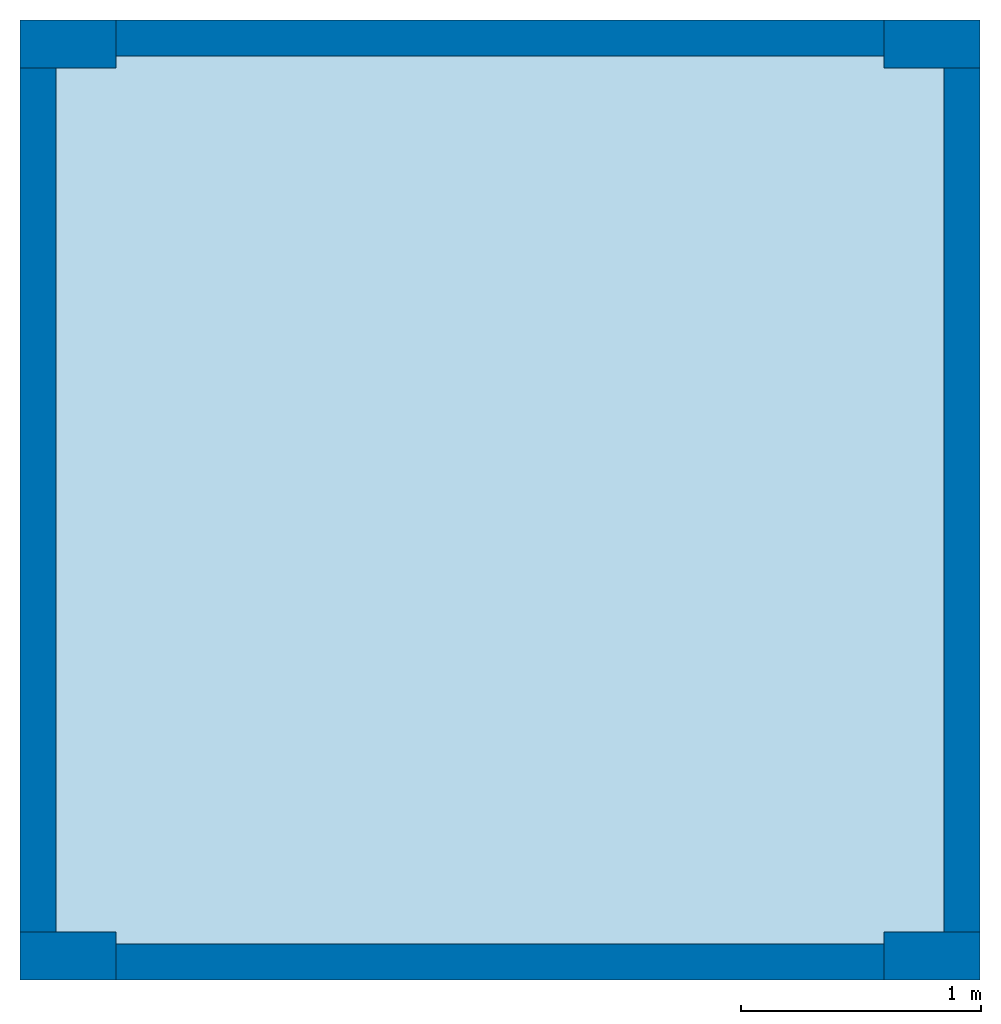
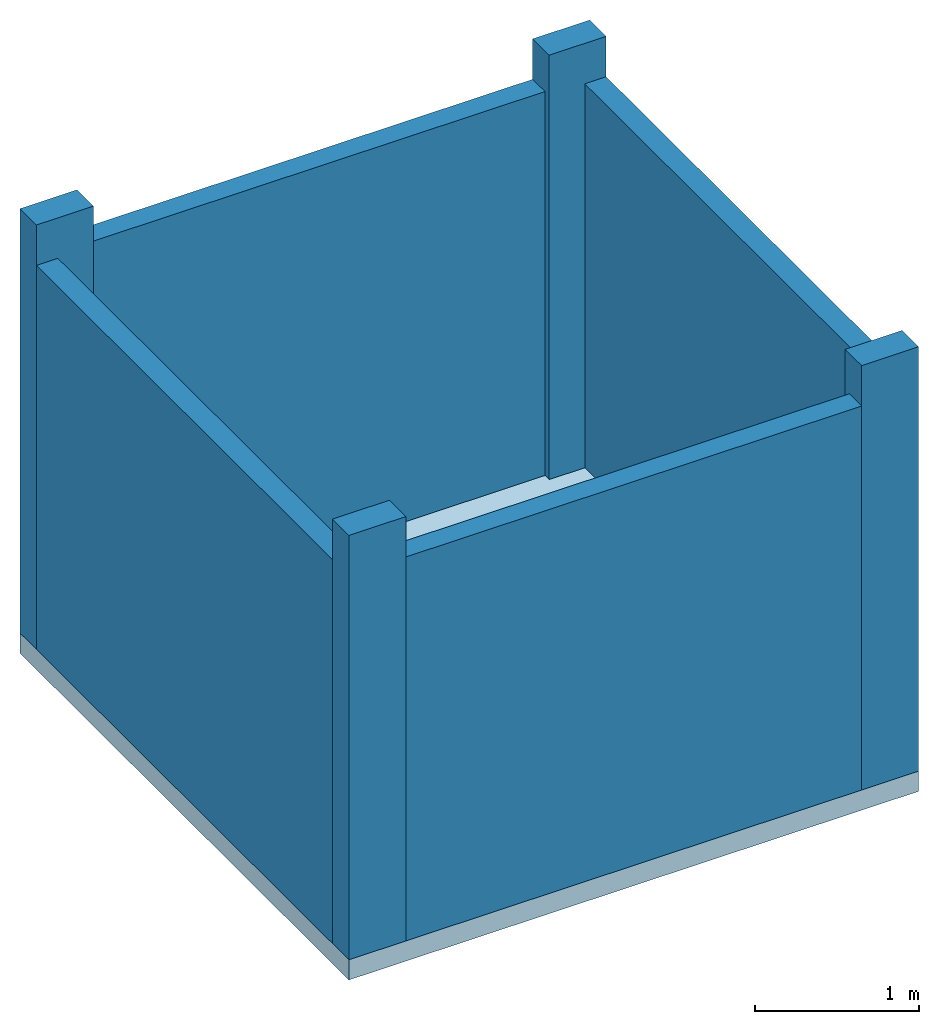
# One storey: 5 columns, 4 walls, 1 slab.
"""IFC4 building model written with IfcOpenShell, lengths in metres."""

from ifc_helpers import new_model, entity, si_unit, converted_unit, frame, origin_with_axes, origin_2d_with_axis, place, context, subcontext, project, spatial, line, indexed_curve, rectangle, outline, extrude, material, layer, layer_set, layer_usage, material_profile, profile_set, profile_usage, type_object, element, save


model = new_model("IFC4")

# Units and contexts
model_context = context("Model", 3, precision=1e-05, world=origin_with_axes())
plan_context = context("Plan", 2, precision=1e-05, world=origin_2d_with_axis())
body_context = subcontext(model_context, "Body", "Model", "MODEL_VIEW")
ifc_project = project(units=[si_unit("VOLUMEUNIT", "CUBIC_METRE"), si_unit("LENGTHUNIT", "METRE"), converted_unit("PLANEANGLEUNIT", "degree", entity("IfcReal", 0.0174532925199433), si_unit("PLANEANGLEUNIT", "RADIAN"), dimensions=[0, 0, 0, 0, 0, 0, 0]), si_unit("AREAUNIT", "SQUARE_METRE")], contexts=[model_context, plan_context])

# Site, building, storey
site_placement = place(None, origin_with_axes())
site = spatial("IfcSite", under=ifc_project, at=site_placement)
building_placement = place(site_placement, origin_with_axes())
building = spatial("IfcBuilding", under=site, at=building_placement)
storey_placement = place(building_placement, origin_with_axes())
storey = spatial("IfcBuildingStorey", under=building, at=storey_placement, Name="GF")

# Columns
ifc_material_1 = material(Name="C30-37", Category="concrete")
ifc_material_profile = material_profile(ifc_material_1, rectangle(XDim=0.200000002980232, YDim=0.400000005960464))
ifc_profile_set = profile_set([ifc_material_profile])
ifc_profile_usage_1 = profile_usage(ifc_profile_set, cardinal=1)
column_type = type_object("IfcColumnType", Name="COL-01", PredefinedType="COLUMN", material=ifc_profile_set)
column_1_placement = place(storey_placement, frame((0.0, 0.0, 0.0), z_axis=(0.0, 0.0, 1.0), x_axis=(-2.82129974493717e-07, -0.99999999999996, 0.0)))
element("IfcColumn", 1, at=column_1_placement, inside=storey, type_object=column_type, material=ifc_profile_usage_1, Name="Column", context=body_context, shape_type="SweptSolid", body=[
    extrude(rectangle(XDim=0.200000002980232, YDim=0.400000005960464), frame((-0.100000001490116, 0.200000002980232, 0.0), z_axis=(0.0, 0.0, 1.0), x_axis=(1.0, 0.0, 0.0)), (0.0, 0.0, 1.0), 3.1500000968812),
])
ifc_profile_usage_2 = profile_usage(ifc_profile_set, cardinal=1)
column_2_placement = place(storey_placement, frame((0.0, 0.0, 0.0), z_axis=(0.0, 0.0, 1.0), x_axis=(-2.82129974493717e-07, -0.99999999999996, 0.0)))
element("IfcColumn", 2, at=column_2_placement, inside=storey, type_object=column_type, material=ifc_profile_usage_2, Name="Column", context=body_context, shape_type="SweptSolid", body=[
    extrude(rectangle(XDim=0.200000002980232, YDim=0.400000005960464), frame((-0.100000001490116, 0.200000002980232, 0.0), z_axis=(0.0, 0.0, 1.0), x_axis=(1.0, 0.0, 0.0)), (0.0, 0.0, 1.0), 3.1500000968812),
])
ifc_profile_usage_3 = profile_usage(ifc_profile_set, cardinal=1)
column_3_placement = place(storey_placement, frame((3.59999990463257, 1.12851992639662e-07, 0.0), z_axis=(0.0, 0.0, 1.0), x_axis=(-2.82129974493717e-07, -0.99999999999996, 0.0)))
element("IfcColumn", 3, at=column_3_placement, inside=storey, type_object=column_type, material=ifc_profile_usage_3, Name="Column", context=body_context, shape_type="SweptSolid", body=[
    extrude(rectangle(XDim=0.200000002980232, YDim=0.400000005960464), frame((-0.100000001490116, 0.200000002980232, 0.0), z_axis=(0.0, 0.0, 1.0), x_axis=(1.0, 0.0, 0.0)), (0.0, 0.0, 1.0), 3.1500000968812),
])
ifc_profile_usage_4 = profile_usage(ifc_profile_set, cardinal=1)
column_4_placement = place(storey_placement, frame((-5.6425996319831e-08, 3.79999995231628, 0.0), z_axis=(0.0, 0.0, 1.0), x_axis=(-2.82129974493717e-07, -0.99999999999996, 0.0)))
element("IfcColumn", 4, at=column_4_placement, inside=storey, type_object=column_type, material=ifc_profile_usage_4, Name="Column", context=body_context, shape_type="SweptSolid", body=[
    extrude(rectangle(XDim=0.200000002980232, YDim=0.400000005960464), frame((-0.100000001490116, 0.200000002980232, 0.0), z_axis=(0.0, 0.0, 1.0), x_axis=(1.0, 0.0, 0.0)), (0.0, 0.0, 1.0), 3.1500000968812),
])
ifc_profile_usage_5 = profile_usage(ifc_profile_set, cardinal=1)
column_5_placement = place(storey_placement, frame((3.59999990463257, 3.79999995231628, 0.0), z_axis=(0.0, 0.0, 1.0), x_axis=(-2.82129974493717e-07, -0.99999999999996, 0.0)))
element("IfcColumn", 5, at=column_5_placement, inside=storey, type_object=column_type, material=ifc_profile_usage_5, Name="Column", context=body_context, shape_type="SweptSolid", body=[
    extrude(rectangle(XDim=0.200000002980232, YDim=0.400000005960464), frame((-0.100000001490116, 0.200000002980232, 0.0), z_axis=(0.0, 0.0, 1.0), x_axis=(1.0, 0.0, 0.0)), (0.0, 0.0, 1.0), 3.1500000968812),
])

# Slab
ifc_material_2 = material(Name="C25-30", Category="concrete")
ifc_layer_1 = layer(ifc_material_2, 0.150000005960464, Name="concrete")
ifc_layer_set_1 = layer_set([ifc_layer_1], Name="raft slab")
ifc_layer_usage_1 = layer_usage(ifc_layer_set_1, "AXIS3", "POSITIVE", 0.0)
slab_type = type_object("IfcSlabType", Name="SLB-01", PredefinedType="BASESLAB", material=ifc_layer_set_1)
slab_placement = place(storey_placement, frame((0.0, 0.0, -0.150000005960464), z_axis=(0.0, 0.0, 1.0), x_axis=(1.0, 0.0, 0.0)))
element("IfcSlab", 6, at=slab_placement, inside=storey, type_object=slab_type, material=ifc_layer_usage_1, Name="Slab", context=body_context, shape_type="SweptSolid", body=[
    extrude(outline(indexed_curve([(0.0, 0.0), (4.0, 0.0), (4.0, 4.0), (0.0, 4.0)], segments=[line(4, 1), line(1, 2), line(2, 3), line(3, 4)], self_intersect=False)), None, (0.0, 0.0, 1.0), 0.150000005960464),
])

# Walls
ifc_material_3 = material(Name="BLK-02", Category="masonry")
ifc_layer_2 = layer(ifc_material_3, 0.150000005960464)
ifc_layer_set_2 = layer_set([ifc_layer_2])
ifc_layer_usage_2 = layer_usage(ifc_layer_set_2, "AXIS2", "POSITIVE", 0.0)
wall_type = type_object("IfcWallType", Name="WAL-02", PredefinedType="SOLIDWALL", material=ifc_layer_set_2)
wall_1_placement = place(storey_placement, frame((0.400000005960464, -1.19209289550781e-07, 0.0), z_axis=(0.0, 0.0, 1.0), x_axis=(1.0, 0.0, 0.0)))
element("IfcWall", 7, at=wall_1_placement, inside=storey, type_object=wall_type, material=ifc_layer_usage_2, Name="Wall", context=body_context, shape_type="SweptSolid", body=[
    extrude(outline(indexed_curve([(0.0, 0.0), (0.0, 0.150000005960464), (3.1999998152256, 0.150000005960464), (3.1999998152256, 0.0), (0.0, 0.0)], self_intersect=False)), origin_with_axes(), (0.0, 0.0, 1.0), 2.84999990463257),
])
ifc_layer_usage_3 = layer_usage(ifc_layer_set_2, "AXIS2", "POSITIVE", 0.0)
wall_2_placement = place(storey_placement, frame((4.0, 0.200000047683716, 0.0), z_axis=(0.0, 0.0, 1.0), x_axis=(3.13916473260163e-07, 0.999999999999951, 0.0)))
element("IfcWall", 8, at=wall_2_placement, inside=storey, type_object=wall_type, material=ifc_layer_usage_3, Name="Wall", context=body_context, shape_type="SweptSolid", body=[
    extrude(outline(indexed_curve([(0.0, 0.0), (0.0, 0.150000005960464), (3.59999987284393, 0.150000005960464), (3.59999987284393, 0.0), (0.0, 0.0)], self_intersect=False)), origin_with_axes(), (0.0, 0.0, 1.0), 2.84999990463257),
])
ifc_layer_usage_4 = layer_usage(ifc_layer_set_2, "AXIS2", "POSITIVE", 0.0)
wall_3_placement = place(storey_placement, frame((3.59999990463257, 4.0, 0.0), z_axis=(0.0, 0.0, 1.0), x_axis=(-0.999999999999924, 3.89414367418765e-07, 0.0)))
element("IfcWall", 9, at=wall_3_placement, inside=storey, type_object=wall_type, material=ifc_layer_usage_4, Name="Wall", context=body_context, shape_type="SweptSolid", body=[
    extrude(outline(indexed_curve([(0.0, 0.0), (0.0, 0.150000005960464), (3.19999981522592, 0.150000005960464), (3.19999981522592, 0.0), (0.0, 0.0)], self_intersect=False)), origin_with_axes(), (0.0, 0.0, 1.0), 2.84999990463257),
])
ifc_layer_usage_5 = layer_usage(ifc_layer_set_2, "AXIS2", "POSITIVE", 0.0)
wall_4_placement = place(storey_placement, frame((-5.96046447753906e-08, 3.79999995231628, 0.0), z_axis=(0.0, 0.0, 1.0), x_axis=(-5.2054855359522e-07, -0.999999999999865, 0.0)))
element("IfcWall", 10, at=wall_4_placement, inside=storey, type_object=wall_type, material=ifc_layer_usage_5, Name="Wall", context=body_context, shape_type="SweptSolid", body=[
    extrude(outline(indexed_curve([(0.0, 0.0), (0.0, 0.150000005960464), (3.60000013775344, 0.150000005960464), (3.60000013775344, 0.0), (0.0, 0.0)], self_intersect=False)), origin_with_axes(), (0.0, 0.0, 1.0), 2.84999990463257),
])

save(model, "model.ifc")
